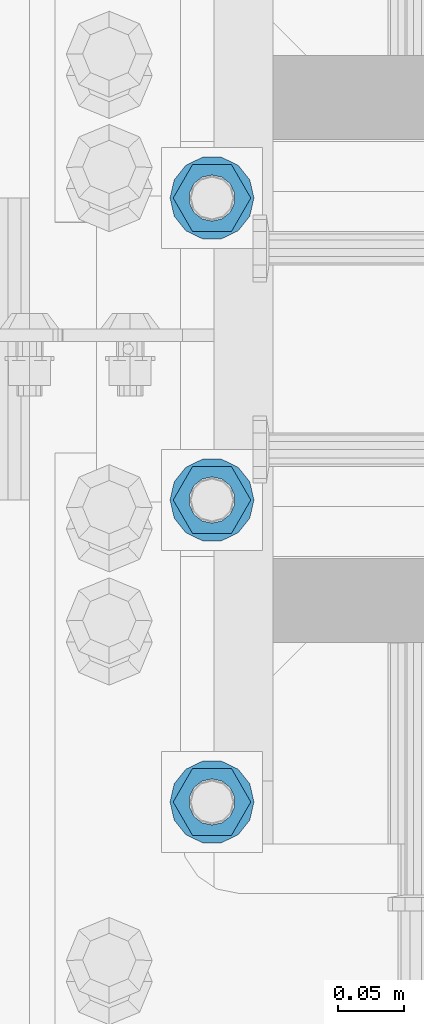
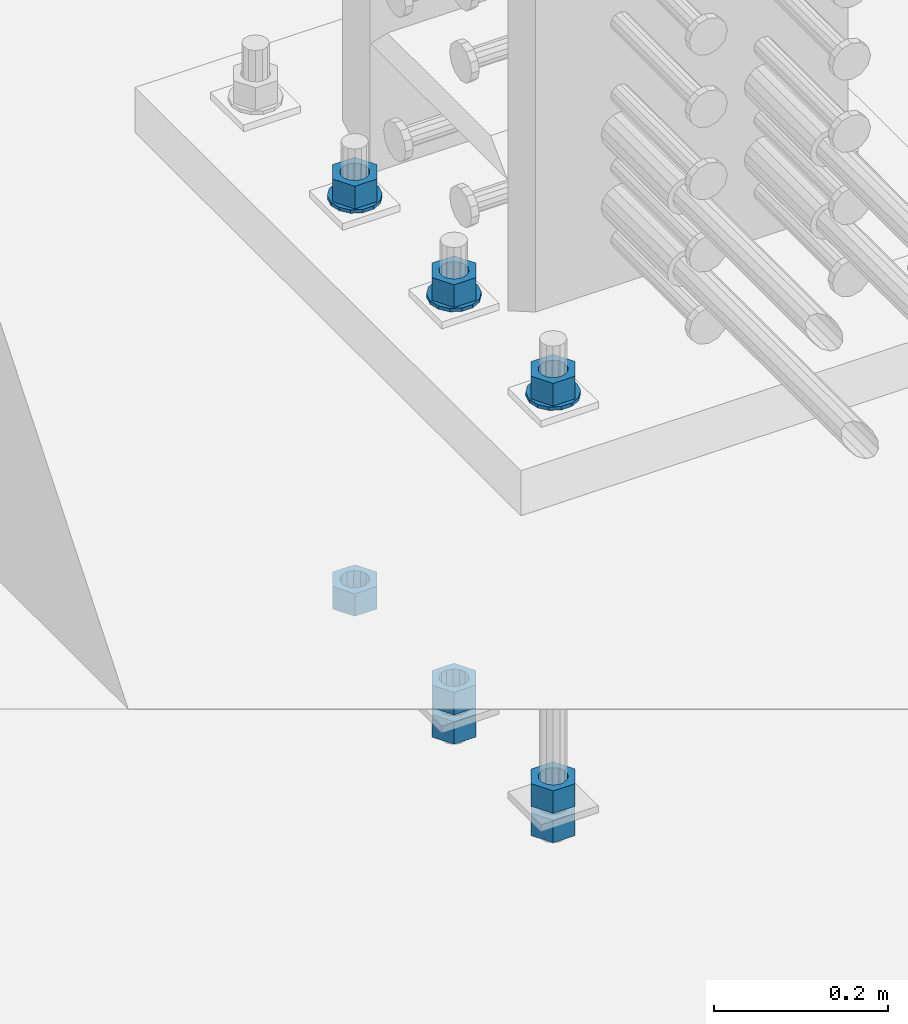
# One storey, part 1010 of 1763: 11 columns, 1 element without a shape of its own.
"""IFC2X3 building model written with IfcOpenShell, lengths in millimetres."""

import ifcopenshell
import ifcopenshell.guid

model = None  # the IFC model being written
_history = None  # IfcOwnerHistory: only IFC2X3 demands one
_inside = {}  # id of a spatial element -> (the spatial element, [elements in it])
_under = {}  # id of a project, library or spatial element -> (it, [spatial elements below it])
_declared = {}  # id of a project -> (the project, [libraries it declares])
_typed = {}  # id of a type object -> (the type object, [elements of that type])
_made_of = {}  # id of a material, layer set ... -> (it, [elements and type objects made of it])


def new_model(schema):
    """Start an empty IFC model of exactly this schema.

    Asked for "IFC4X3", IfcOpenShell would pick the latest addendum, in which some entities
    have other attributes; the version numbers below select the first issue.
    IFC2X3 requires an IfcOwnerHistory on every rooted entity: one is made here for all.
    """
    global model, _history
    if schema == "IFC4X3":
        model = ifcopenshell.file(schema_version=(4, 3, 0, 0))
    else:
        model = ifcopenshell.file(schema=schema)
    _inside.clear()
    _under.clear()
    _declared.clear()
    _typed.clear()
    _made_of.clear()
    _history = None
    if model.schema == "IFC2X3":
        org = make("IfcOrganization", Name="unknown")
        user = make(
            "IfcPersonAndOrganization",
            ThePerson=make("IfcPerson", FamilyName="unknown"),
            TheOrganization=org,
        )
        app = make(
            "IfcApplication",
            ApplicationDeveloper=org,
            Version="unknown",
            ApplicationFullName="unknown",
            ApplicationIdentifier="unknown",
        )
        _history = make(
            "IfcOwnerHistory",
            OwningUser=user,
            OwningApplication=app,
            ChangeAction="ADDED",
            CreationDate=0,
        )
    return model


def make(cls, **values):
    """One entity of the class cls with the attributes given. An attribute that is None is left unset."""
    return model.create_entity(
        cls, **{name: value for name, value in values.items() if value is not None}
    )


def rooted(cls, **values):
    """An entity with a GlobalId (a new one), such as an element, a storey or a relation."""
    return make(cls, GlobalId=ifcopenshell.guid.new(), OwnerHistory=_history, **values)


def si_unit(unit_type, name, prefix=None):
    """IfcSIUnit, for example si_unit("LENGTHUNIT", "METRE", prefix="MILLI")."""
    return make("IfcSIUnit", UnitType=unit_type, Prefix=prefix, Name=name)


def assignment(units):
    """IfcUnitAssignment: the units of a project."""
    return None if units is None else make("IfcUnitAssignment", Units=units)


def point(xyz):
    """IfcCartesianPoint."""
    return None if xyz is None else make("IfcCartesianPoint", Coordinates=xyz)


def direction(xyz):
    """IfcDirection."""
    return None if xyz is None else make("IfcDirection", DirectionRatios=xyz)


def frame(location, z_axis=None, x_axis=None):
    """IfcAxis2Placement3D, a coordinate frame: its origin and axes. An axis left out is left unset."""
    return make(
        "IfcAxis2Placement3D",
        Location=point(location),
        Axis=direction(z_axis),
        RefDirection=direction(x_axis),
    )


def origin_with_axes():
    """The frame at (0, 0, 0) with the z axis (0, 0, 1) and the x axis (1, 0, 0) written out."""
    return frame((0.0, 0.0, 0.0), z_axis=(0.0, 0.0, 1.0), x_axis=(1.0, 0.0, 0.0))


def place(relative_to, where):
    """IfcLocalPlacement: puts the frame where relative to a parent placement (None: the world)."""
    return make(
        "IfcLocalPlacement", PlacementRelTo=relative_to, RelativePlacement=where
    )


def context(
    kind, dimensions, precision=None, world=None, true_north=None, identifier=None
):
    """IfcGeometricRepresentationContext, for example the 3D "Model" context."""
    return make(
        "IfcGeometricRepresentationContext",
        ContextIdentifier=identifier,
        ContextType=kind,
        CoordinateSpaceDimension=dimensions,
        Precision=precision,
        WorldCoordinateSystem=world,
        TrueNorth=true_north,
    )


def subcontext(parent, identifier, kind, view, scale=None):
    """IfcGeometricRepresentationSubContext, for example "Body" below "Model"."""
    return make(
        "IfcGeometricRepresentationSubContext",
        ContextIdentifier=identifier,
        ContextType=kind,
        ParentContext=parent,
        TargetScale=scale,
        TargetView=view,
    )


def project(units=None, contexts=None):
    """IfcProject with its units and contexts."""
    return rooted(
        "IfcProject",
        Name="project",
        RepresentationContexts=contexts,
        UnitsInContext=assignment(units),
    )


def spatial(cls, under=None, at=None, **own):
    """A site, building, storey or space (cls), placed at a placement, below another one or the project."""
    s = rooted(cls, ObjectPlacement=at, **own)
    if under is not None:
        _under.setdefault(under.id(), (under, []))[1].append(s)
    return s


def faces_of(points, faces, orient=None, outer=None):
    """IfcFace entities. A face is a list of loops; a loop is a list of indices into points, from 0.

    orient and outer hold one flag for each loop. By default every Orientation is true, the
    first loop of a face is its IfcFaceOuterBound and the others are IfcFaceBound.
    """
    made = []
    for i, loops in enumerate(faces):
        bounds = []
        for j, loop in enumerate(loops):
            is_outer = j == 0 if outer is None else outer[i][j]
            bounds.append(
                make(
                    "IfcFaceOuterBound" if is_outer else "IfcFaceBound",
                    Bound=make("IfcPolyLoop", Polygon=[points[k] for k in loop]),
                    Orientation=True if orient is None else orient[i][j],
                )
            )
        made.append(make("IfcFace", Bounds=bounds))
    return made


def faceted_brep(points, faces, orient=None, outer=None, voids=None):
    """IfcFacetedBrep: a solid bounded by flat faces; with voids (closed shells), ...WithVoids."""
    shared = [point(p) for p in points]
    hull = make("IfcClosedShell", CfsFaces=faces_of(shared, faces, orient, outer))
    if voids is None:
        return make("IfcFacetedBrep", Outer=hull)
    return make(
        "IfcFacetedBrepWithVoids",
        Outer=hull,
        Voids=[
            make(cls, CfsFaces=faces_of(shared, fs, o, b)) for cls, fs, o, b in voids
        ],
    )


def shape(context_of_items, identifier, shape_type, items):
    """IfcShapeRepresentation: the items that make up one representation, for example the "Body"."""
    return make(
        "IfcShapeRepresentation",
        ContextOfItems=context_of_items,
        RepresentationIdentifier=identifier,
        RepresentationType=shape_type,
        Items=items,
    )


def material(Name=None, Category=None):
    """IfcMaterial."""
    return make("IfcMaterial", Name=Name, Category=Category)


def made_of(thing, what):
    """Note that an element or type object is made of a material, layer set ...; save() writes the relation."""
    if what is not None:
        _made_of.setdefault(what.id(), (what, []))[1].append(thing)
    return thing


def type_object(cls, material=None, **own):
    """A type object (cls), such as IfcWallType, which elements share."""
    return made_of(rooted(cls, **own), material)


def element(
    cls,
    number,
    at=None,
    inside=None,
    cuts=None,
    type_object=None,
    material=None,
    context=None,
    identifier="Body",
    shape_type=None,
    held_by="IfcProductDefinitionShape",
    body=None,
    shapes=None,
    **own,
):
    """One element of the class cls, such as IfcWall. Its Tag is "e" and its number.

    at: its placement. inside: the storey or other place that contains it. cuts: it is an
    opening in that element (IfcRelVoidsElement). A single representation is given by context,
    identifier, shape_type and body (its items); several are given by shapes. held_by: the class
    of the entity that holds the representations. save() writes the other relations.
    """
    e = rooted(cls, Tag="e%d" % number, ObjectPlacement=at, **own)
    if body is not None:
        shapes = [shape(context, identifier, shape_type, body)]
    if shapes is not None:
        e.Representation = make(held_by, Representations=shapes)
    if inside is not None:
        _inside.setdefault(inside.id(), (inside, []))[1].append(e)
    if cuts is not None:
        rooted(
            "IfcRelVoidsElement", RelatingBuildingElement=cuts, RelatedOpeningElement=e
        )
    if type_object is not None:
        _typed.setdefault(type_object.id(), (type_object, []))[1].append(e)
    return made_of(e, material)


def aggregate(whole, parts):
    """IfcRelAggregates: a whole, such as a stair, and the parts it consists of."""
    return rooted("IfcRelAggregates", RelatingObject=whole, RelatedObjects=parts)


def save(model, path):
    """Write the relations noted so far, then the file.

    IfcRelAggregates (storeys below a building ...), IfcRelContainedInSpatialStructure (elements
    in a storey), IfcRelDefinesByType, IfcRelAssociatesMaterial and IfcRelDeclares: one each for
    every whole, place, type object, material and project.
    """
    for whole, parts in _under.values():
        aggregate(whole, parts)
    for where, things in _inside.values():
        rooted(
            "IfcRelContainedInSpatialStructure",
            RelatedElements=things,
            RelatingStructure=where,
        )
    for kind, things in _typed.values():
        rooted("IfcRelDefinesByType", RelatedObjects=things, RelatingType=kind)
    for what, things in _made_of.values():
        rooted("IfcRelAssociatesMaterial", RelatedObjects=things, RelatingMaterial=what)
    for by, libraries in _declared.values():
        rooted("IfcRelDeclares", RelatingContext=by, RelatedDefinitions=libraries)
    model.write(path)


model = new_model("IFC2X3")

# Units and contexts
model_context = context("Model", 3, precision=1e-05, world=origin_with_axes())
body_context = subcontext(model_context, "Body", "Model", "MODEL_VIEW")
ifc_project = project(units=[si_unit("LENGTHUNIT", "METRE", prefix="MILLI"), si_unit("AREAUNIT", "SQUARE_METRE"), si_unit("VOLUMEUNIT", "CUBIC_METRE"), si_unit("MASSUNIT", "GRAM", prefix="KILO"), si_unit("TIMEUNIT", "SECOND"), si_unit("PLANEANGLEUNIT", "RADIAN"), si_unit("SOLIDANGLEUNIT", "STERADIAN"), si_unit("THERMODYNAMICTEMPERATUREUNIT", "DEGREE_CELSIUS"), si_unit("LUMINOUSINTENSITYUNIT", "LUMEN")], contexts=[model_context])

# Site, building, storey
site_placement = place(None, origin_with_axes())
site = spatial("IfcSite", under=ifc_project, at=site_placement, CompositionType="ELEMENT")
building_placement = place(site_placement, origin_with_axes())
building = spatial("IfcBuilding", under=site, at=building_placement, Name="Undefined", CompositionType="ELEMENT")
storey_placement = place(building_placement, origin_with_axes())
storey = spatial("IfcBuildingStorey", under=building, at=storey_placement, Name="Undefined", CompositionType="ELEMENT", Elevation=0.0)

# Assembly, columns
assembly_placement = place(storey_placement, origin_with_axes())
assembly = element("IfcElementAssembly", 1, at=assembly_placement, inside=storey, Name="TEMPLATE", AssemblyPlace="NOTDEFINED", PredefinedType="RIGID_FRAME")
ifc_material_1 = material(Name="STEEL/A563")
column_type_1 = type_object("IfcColumnType", Name="1-1/4_HEAVY_HEX_NUT", PredefinedType="NOTDEFINED")
column_1_placement = place(assembly_placement, frame((-24281.8372736984, 114.299999999998, 3957.6375), z_axis=(0.0, -1.0, 0.0), x_axis=(0.0, 0.0, -1.0)))
column_1 = element("IfcColumn", 2, at=column_1_placement, type_object=column_type_1, material=ifc_material_1, Name="NUT", ObjectType="1-1/4_HEAVY_HEX_NUT", context=body_context, shape_type="Brep", body=[
    faceted_brep([(0.0, -29.3700008392334, 0.0), (0.0, -14.6800003051758, -25.4300003051758), (31.75, -14.6800003051758, -25.4300003051758), (31.75, -29.3700008392334, 0.0), (0.0, 14.6800003051758, -25.4300003051758), (31.75, 14.6800003051758, -25.4300003051758), (0.0, 29.3700008392334, 0.0), (31.75, 29.3700008392334, 0.0), (0.0, 14.6800003051758, 25.4300003051758), (31.75, 14.6800003051758, 25.4300003051758), (0.0, -14.6800003051758, 25.4300003051758), (31.75, -14.6800003051758, 25.4300003051758), (0.0, 0.0, 17.4599990844727), (0.0, 7.57560968776022, 15.730915608714), (31.75, 7.57560968775942, 15.7309156087145), (31.75, 0.0, 17.4599990844727), (0.0, 13.6507769681037, 10.8861313696252), (31.75, 13.6507769681048, 10.8861313696314), (0.0, 17.0222404541215, 3.88521530314756), (31.75, 17.02224045412, 3.88521530315316), (0.0, 17.0222404541215, -3.88521530314756), (31.75, 17.02224045412, -3.88521530315332), (0.0, 13.6507769681037, -10.8861313696252), (31.75, 13.6507769681048, -10.8861313696316), (0.0, 7.57560968776022, -15.730915608714), (31.75, 7.57560968775942, -15.7309156087146), (0.0, 0.0, -17.4599990844727), (31.75, 0.0, -17.4599990844727), (0.0, -7.57560968776022, -15.730915608714), (31.75, -7.57560968775942, -15.7309156087145), (0.0, -13.6507769681037, -10.8861313696252), (31.75, -13.6507769681048, -10.8861313696314), (0.0, -17.0222404541215, -3.88521530314756), (31.75, -17.02224045412, -3.88521530315316), (0.0, -17.0222404541215, 3.88521530314756), (31.75, -17.02224045412, 3.88521530315332), (0.0, -13.6507769681037, 10.8861313696252), (31.75, -13.6507769681048, 10.8861313696316), (0.0, -7.57560968776022, 15.730915608714), (31.75, -7.57560968775942, 15.7309156087146)], [[[0, 1, 2, 3]], [[1, 4, 5, 2]], [[4, 6, 7, 5]], [[6, 8, 9, 7]], [[8, 10, 11, 9]], [[10, 0, 3, 11]], [[12, 13, 14, 15]], [[13, 16, 17, 14]], [[16, 18, 19, 17]], [[18, 20, 21, 19]], [[20, 22, 23, 21]], [[22, 24, 25, 23]], [[24, 26, 27, 25]], [[26, 28, 29, 27]], [[28, 30, 31, 29]], [[30, 32, 33, 31]], [[32, 34, 35, 33]], [[34, 36, 37, 35]], [[36, 38, 39, 37]], [[38, 12, 15, 39]], [[5, 7, 9, 11, 3, 2], [17, 19, 21, 23, 25, 27, 29, 31, 33, 35, 37, 39, 15, 14]], [[10, 8, 6, 4, 1, 0], [38, 36, 34, 32, 30, 28, 26, 24, 22, 20, 18, 16, 13, 12]]]),
])
column_2_placement = place(assembly_placement, frame((-24281.8372736984, 114.299999999998, 3384.55), z_axis=(0.0, -1.0, 0.0), x_axis=(0.0, 0.0, -1.0)))
column_2 = element("IfcColumn", 3, at=column_2_placement, type_object=column_type_1, material=ifc_material_1, Name="NUT", ObjectType="1-1/4_HEAVY_HEX_NUT", context=body_context, shape_type="Brep", body=[
    faceted_brep([(0.0, -29.3700008392334, 0.0), (0.0, -14.6800003051758, -25.4300003051758), (31.75, -14.6800003051758, -25.4300003051758), (31.75, -29.3700008392334, 0.0), (0.0, 14.6800003051758, -25.4300003051758), (31.75, 14.6800003051758, -25.4300003051758), (0.0, 29.3700008392334, 0.0), (31.75, 29.3700008392334, 0.0), (0.0, 14.6800003051758, 25.4300003051758), (31.75, 14.6800003051758, 25.4300003051758), (0.0, -14.6800003051758, 25.4300003051758), (31.75, -14.6800003051758, 25.4300003051758), (0.0, 0.0, 17.4599990844727), (0.0, 7.57560968776022, 15.730915608714), (31.75, 7.57560968775942, 15.7309156087145), (31.75, 0.0, 17.4599990844727), (0.0, 13.6507769681037, 10.8861313696252), (31.75, 13.6507769681048, 10.8861313696314), (0.0, 17.0222404541215, 3.88521530314756), (31.75, 17.02224045412, 3.88521530315316), (0.0, 17.0222404541215, -3.88521530314756), (31.75, 17.02224045412, -3.88521530315332), (0.0, 13.6507769681037, -10.8861313696252), (31.75, 13.6507769681048, -10.8861313696316), (0.0, 7.57560968776022, -15.730915608714), (31.75, 7.57560968775942, -15.7309156087146), (0.0, 0.0, -17.4599990844727), (31.75, 0.0, -17.4599990844727), (0.0, -7.57560968776022, -15.730915608714), (31.75, -7.57560968775942, -15.7309156087145), (0.0, -13.6507769681037, -10.8861313696252), (31.75, -13.6507769681048, -10.8861313696314), (0.0, -17.0222404541215, -3.88521530314756), (31.75, -17.02224045412, -3.88521530315316), (0.0, -17.0222404541215, 3.88521530314756), (31.75, -17.02224045412, 3.88521530315332), (0.0, -13.6507769681037, 10.8861313696252), (31.75, -13.6507769681048, 10.8861313696316), (0.0, -7.57560968776022, 15.730915608714), (31.75, -7.57560968775942, 15.7309156087146)], [[[0, 1, 2, 3]], [[1, 4, 5, 2]], [[4, 6, 7, 5]], [[6, 8, 9, 7]], [[8, 10, 11, 9]], [[10, 0, 3, 11]], [[12, 13, 14, 15]], [[13, 16, 17, 14]], [[16, 18, 19, 17]], [[18, 20, 21, 19]], [[20, 22, 23, 21]], [[22, 24, 25, 23]], [[24, 26, 27, 25]], [[26, 28, 29, 27]], [[28, 30, 31, 29]], [[30, 32, 33, 31]], [[32, 34, 35, 33]], [[34, 36, 37, 35]], [[36, 38, 39, 37]], [[38, 12, 15, 39]], [[5, 7, 9, 11, 3, 2], [17, 19, 21, 23, 25, 27, 29, 31, 33, 35, 37, 39, 15, 14]], [[10, 8, 6, 4, 1, 0], [38, 36, 34, 32, 30, 28, 26, 24, 22, 20, 18, 16, 13, 12]]]),
])
column_3_placement = place(assembly_placement, frame((-24281.8372736984, 114.299999999998, 3343.275), z_axis=(0.0, -1.0, 0.0), x_axis=(0.0, 0.0, -1.0)))
column_3 = element("IfcColumn", 4, at=column_3_placement, type_object=column_type_1, material=ifc_material_1, Name="NUT", ObjectType="1-1/4_HEAVY_HEX_NUT", context=body_context, shape_type="Brep", body=[
    faceted_brep([(0.0, -29.3700008392334, 0.0), (0.0, -14.6800003051758, -25.4300003051758), (31.75, -14.6800003051758, -25.4300003051758), (31.75, -29.3700008392334, 0.0), (0.0, 14.6800003051758, -25.4300003051758), (31.75, 14.6800003051758, -25.4300003051758), (0.0, 29.3700008392334, 0.0), (31.75, 29.3700008392334, 0.0), (0.0, 14.6800003051758, 25.4300003051758), (31.75, 14.6800003051758, 25.4300003051758), (0.0, -14.6800003051758, 25.4300003051758), (31.75, -14.6800003051758, 25.4300003051758), (0.0, 0.0, 17.4599990844727), (0.0, 7.57560968776022, 15.730915608714), (31.75, 7.57560968775942, 15.7309156087145), (31.75, 0.0, 17.4599990844727), (0.0, 13.6507769681037, 10.8861313696252), (31.75, 13.6507769681048, 10.8861313696314), (0.0, 17.0222404541215, 3.88521530314756), (31.75, 17.02224045412, 3.88521530315316), (0.0, 17.0222404541215, -3.88521530314756), (31.75, 17.02224045412, -3.88521530315332), (0.0, 13.6507769681037, -10.8861313696252), (31.75, 13.6507769681048, -10.8861313696316), (0.0, 7.57560968776022, -15.730915608714), (31.75, 7.57560968775942, -15.7309156087146), (0.0, 0.0, -17.4599990844727), (31.75, 0.0, -17.4599990844727), (0.0, -7.57560968776022, -15.730915608714), (31.75, -7.57560968775942, -15.7309156087145), (0.0, -13.6507769681037, -10.8861313696252), (31.75, -13.6507769681048, -10.8861313696314), (0.0, -17.0222404541215, -3.88521530314756), (31.75, -17.02224045412, -3.88521530315316), (0.0, -17.0222404541215, 3.88521530314756), (31.75, -17.02224045412, 3.88521530315332), (0.0, -13.6507769681037, 10.8861313696252), (31.75, -13.6507769681048, 10.8861313696316), (0.0, -7.57560968776022, 15.730915608714), (31.75, -7.57560968775942, 15.7309156087146)], [[[0, 1, 2, 3]], [[1, 4, 5, 2]], [[4, 6, 7, 5]], [[6, 8, 9, 7]], [[8, 10, 11, 9]], [[10, 0, 3, 11]], [[12, 13, 14, 15]], [[13, 16, 17, 14]], [[16, 18, 19, 17]], [[18, 20, 21, 19]], [[20, 22, 23, 21]], [[22, 24, 25, 23]], [[24, 26, 27, 25]], [[26, 28, 29, 27]], [[28, 30, 31, 29]], [[30, 32, 33, 31]], [[32, 34, 35, 33]], [[34, 36, 37, 35]], [[36, 38, 39, 37]], [[38, 12, 15, 39]], [[5, 7, 9, 11, 3, 2], [17, 19, 21, 23, 25, 27, 29, 31, 33, 35, 37, 39, 15, 14]], [[10, 8, 6, 4, 1, 0], [38, 36, 34, 32, 30, 28, 26, 24, 22, 20, 18, 16, 13, 12]]]),
])
column_4_placement = place(assembly_placement, frame((-24281.8372736984, 342.899999999998, 3957.6375), z_axis=(0.0, -1.0, 0.0), x_axis=(0.0, 0.0, -1.0)))
column_4 = element("IfcColumn", 5, at=column_4_placement, type_object=column_type_1, material=ifc_material_1, Name="NUT", ObjectType="1-1/4_HEAVY_HEX_NUT", context=body_context, shape_type="Brep", body=[
    faceted_brep([(0.0, -29.3700008392334, 0.0), (0.0, -14.6800003051758, -25.4300003051758), (31.75, -14.6800003051758, -25.4300003051758), (31.75, -29.3700008392334, 0.0), (0.0, 14.6800003051758, -25.4300003051758), (31.75, 14.6800003051758, -25.4300003051758), (0.0, 29.3700008392334, 0.0), (31.75, 29.3700008392334, 0.0), (0.0, 14.6800003051758, 25.4300003051758), (31.75, 14.6800003051758, 25.4300003051758), (0.0, -14.6800003051758, 25.4300003051758), (31.75, -14.6800003051758, 25.4300003051758), (0.0, 0.0, 17.4599990844727), (0.0, 7.57560968776022, 15.730915608714), (31.75, 7.57560968775942, 15.7309156087145), (31.75, 0.0, 17.4599990844727), (0.0, 13.6507769681037, 10.8861313696252), (31.75, 13.6507769681048, 10.8861313696314), (0.0, 17.0222404541215, 3.88521530314756), (31.75, 17.02224045412, 3.88521530315316), (0.0, 17.0222404541215, -3.88521530314756), (31.75, 17.02224045412, -3.88521530315332), (0.0, 13.6507769681037, -10.8861313696252), (31.75, 13.6507769681048, -10.8861313696316), (0.0, 7.57560968776022, -15.730915608714), (31.75, 7.57560968775942, -15.7309156087146), (0.0, 0.0, -17.4599990844727), (31.75, 0.0, -17.4599990844727), (0.0, -7.57560968776022, -15.730915608714), (31.75, -7.57560968775942, -15.7309156087145), (0.0, -13.6507769681037, -10.8861313696252), (31.75, -13.6507769681048, -10.8861313696314), (0.0, -17.0222404541215, -3.88521530314756), (31.75, -17.02224045412, -3.88521530315316), (0.0, -17.0222404541215, 3.88521530314756), (31.75, -17.02224045412, 3.88521530315332), (0.0, -13.6507769681037, 10.8861313696252), (31.75, -13.6507769681048, 10.8861313696316), (0.0, -7.57560968776022, 15.730915608714), (31.75, -7.57560968775942, 15.7309156087146)], [[[0, 1, 2, 3]], [[1, 4, 5, 2]], [[4, 6, 7, 5]], [[6, 8, 9, 7]], [[8, 10, 11, 9]], [[10, 0, 3, 11]], [[12, 13, 14, 15]], [[13, 16, 17, 14]], [[16, 18, 19, 17]], [[18, 20, 21, 19]], [[20, 22, 23, 21]], [[22, 24, 25, 23]], [[24, 26, 27, 25]], [[26, 28, 29, 27]], [[28, 30, 31, 29]], [[30, 32, 33, 31]], [[32, 34, 35, 33]], [[34, 36, 37, 35]], [[36, 38, 39, 37]], [[38, 12, 15, 39]], [[5, 7, 9, 11, 3, 2], [17, 19, 21, 23, 25, 27, 29, 31, 33, 35, 37, 39, 15, 14]], [[10, 8, 6, 4, 1, 0], [38, 36, 34, 32, 30, 28, 26, 24, 22, 20, 18, 16, 13, 12]]]),
])
column_5_placement = place(assembly_placement, frame((-24281.8372736984, 342.899999999998, 3384.55), z_axis=(0.0, -1.0, 0.0), x_axis=(0.0, 0.0, -1.0)))
column_5 = element("IfcColumn", 6, at=column_5_placement, type_object=column_type_1, material=ifc_material_1, Name="NUT", ObjectType="1-1/4_HEAVY_HEX_NUT", context=body_context, shape_type="Brep", body=[
    faceted_brep([(0.0, -29.3700008392334, 0.0), (0.0, -14.6800003051758, -25.4300003051758), (31.75, -14.6800003051758, -25.4300003051758), (31.75, -29.3700008392334, 0.0), (0.0, 14.6800003051758, -25.4300003051758), (31.75, 14.6800003051758, -25.4300003051758), (0.0, 29.3700008392334, 0.0), (31.75, 29.3700008392334, 0.0), (0.0, 14.6800003051758, 25.4300003051758), (31.75, 14.6800003051758, 25.4300003051758), (0.0, -14.6800003051758, 25.4300003051758), (31.75, -14.6800003051758, 25.4300003051758), (0.0, 0.0, 17.4599990844727), (0.0, 7.57560968776022, 15.730915608714), (31.75, 7.57560968775942, 15.7309156087145), (31.75, 0.0, 17.4599990844727), (0.0, 13.6507769681037, 10.8861313696252), (31.75, 13.6507769681048, 10.8861313696314), (0.0, 17.0222404541215, 3.88521530314756), (31.75, 17.02224045412, 3.88521530315316), (0.0, 17.0222404541215, -3.88521530314756), (31.75, 17.02224045412, -3.88521530315332), (0.0, 13.6507769681037, -10.8861313696252), (31.75, 13.6507769681048, -10.8861313696316), (0.0, 7.57560968776022, -15.730915608714), (31.75, 7.57560968775942, -15.7309156087146), (0.0, 0.0, -17.4599990844727), (31.75, 0.0, -17.4599990844727), (0.0, -7.57560968776022, -15.730915608714), (31.75, -7.57560968775942, -15.7309156087145), (0.0, -13.6507769681037, -10.8861313696252), (31.75, -13.6507769681048, -10.8861313696314), (0.0, -17.0222404541215, -3.88521530314756), (31.75, -17.02224045412, -3.88521530315316), (0.0, -17.0222404541215, 3.88521530314756), (31.75, -17.02224045412, 3.88521530315332), (0.0, -13.6507769681037, 10.8861313696252), (31.75, -13.6507769681048, 10.8861313696316), (0.0, -7.57560968776022, 15.730915608714), (31.75, -7.57560968775942, 15.7309156087146)], [[[0, 1, 2, 3]], [[1, 4, 5, 2]], [[4, 6, 7, 5]], [[6, 8, 9, 7]], [[8, 10, 11, 9]], [[10, 0, 3, 11]], [[12, 13, 14, 15]], [[13, 16, 17, 14]], [[16, 18, 19, 17]], [[18, 20, 21, 19]], [[20, 22, 23, 21]], [[22, 24, 25, 23]], [[24, 26, 27, 25]], [[26, 28, 29, 27]], [[28, 30, 31, 29]], [[30, 32, 33, 31]], [[32, 34, 35, 33]], [[34, 36, 37, 35]], [[36, 38, 39, 37]], [[38, 12, 15, 39]], [[5, 7, 9, 11, 3, 2], [17, 19, 21, 23, 25, 27, 29, 31, 33, 35, 37, 39, 15, 14]], [[10, 8, 6, 4, 1, 0], [38, 36, 34, 32, 30, 28, 26, 24, 22, 20, 18, 16, 13, 12]]]),
])
column_6_placement = place(assembly_placement, frame((-24281.8372736984, 342.899999999998, 3343.275), z_axis=(0.0, -1.0, 0.0), x_axis=(0.0, 0.0, -1.0)))
column_6 = element("IfcColumn", 7, at=column_6_placement, type_object=column_type_1, material=ifc_material_1, Name="NUT", ObjectType="1-1/4_HEAVY_HEX_NUT", context=body_context, shape_type="Brep", body=[
    faceted_brep([(0.0, -29.3700008392334, 0.0), (0.0, -14.6800003051758, -25.4300003051758), (31.75, -14.6800003051758, -25.4300003051758), (31.75, -29.3700008392334, 0.0), (0.0, 14.6800003051758, -25.4300003051758), (31.75, 14.6800003051758, -25.4300003051758), (0.0, 29.3700008392334, 0.0), (31.75, 29.3700008392334, 0.0), (0.0, 14.6800003051758, 25.4300003051758), (31.75, 14.6800003051758, 25.4300003051758), (0.0, -14.6800003051758, 25.4300003051758), (31.75, -14.6800003051758, 25.4300003051758), (0.0, 0.0, 17.4599990844727), (0.0, 7.57560968776022, 15.730915608714), (31.75, 7.57560968775942, 15.7309156087145), (31.75, 0.0, 17.4599990844727), (0.0, 13.6507769681037, 10.8861313696252), (31.75, 13.6507769681048, 10.8861313696314), (0.0, 17.0222404541215, 3.88521530314756), (31.75, 17.02224045412, 3.88521530315316), (0.0, 17.0222404541215, -3.88521530314756), (31.75, 17.02224045412, -3.88521530315332), (0.0, 13.6507769681037, -10.8861313696252), (31.75, 13.6507769681048, -10.8861313696316), (0.0, 7.57560968776022, -15.730915608714), (31.75, 7.57560968775942, -15.7309156087146), (0.0, 0.0, -17.4599990844727), (31.75, 0.0, -17.4599990844727), (0.0, -7.57560968776022, -15.730915608714), (31.75, -7.57560968775942, -15.7309156087145), (0.0, -13.6507769681037, -10.8861313696252), (31.75, -13.6507769681048, -10.8861313696314), (0.0, -17.0222404541215, -3.88521530314756), (31.75, -17.02224045412, -3.88521530315316), (0.0, -17.0222404541215, 3.88521530314756), (31.75, -17.02224045412, 3.88521530315332), (0.0, -13.6507769681037, 10.8861313696252), (31.75, -13.6507769681048, 10.8861313696316), (0.0, -7.57560968776022, 15.730915608714), (31.75, -7.57560968775942, 15.7309156087146)], [[[0, 1, 2, 3]], [[1, 4, 5, 2]], [[4, 6, 7, 5]], [[6, 8, 9, 7]], [[8, 10, 11, 9]], [[10, 0, 3, 11]], [[12, 13, 14, 15]], [[13, 16, 17, 14]], [[16, 18, 19, 17]], [[18, 20, 21, 19]], [[20, 22, 23, 21]], [[22, 24, 25, 23]], [[24, 26, 27, 25]], [[26, 28, 29, 27]], [[28, 30, 31, 29]], [[30, 32, 33, 31]], [[32, 34, 35, 33]], [[34, 36, 37, 35]], [[36, 38, 39, 37]], [[38, 12, 15, 39]], [[5, 7, 9, 11, 3, 2], [17, 19, 21, 23, 25, 27, 29, 31, 33, 35, 37, 39, 15, 14]], [[10, 8, 6, 4, 1, 0], [38, 36, 34, 32, 30, 28, 26, 24, 22, 20, 18, 16, 13, 12]]]),
])
column_7_placement = place(assembly_placement, frame((-24281.8372736984, 571.499999999998, 3957.6375), z_axis=(0.0, -1.0, 0.0), x_axis=(0.0, 0.0, -1.0)))
column_7 = element("IfcColumn", 8, at=column_7_placement, type_object=column_type_1, material=ifc_material_1, Name="NUT", ObjectType="1-1/4_HEAVY_HEX_NUT", context=body_context, shape_type="Brep", body=[
    faceted_brep([(0.0, -29.3700008392334, 0.0), (0.0, -14.6800003051758, -25.4300003051758), (31.75, -14.6800003051758, -25.4300003051758), (31.75, -29.3700008392334, 0.0), (0.0, 14.6800003051758, -25.4300003051758), (31.75, 14.6800003051758, -25.4300003051758), (0.0, 29.3700008392334, 0.0), (31.75, 29.3700008392334, 0.0), (0.0, 14.6800003051758, 25.4300003051758), (31.75, 14.6800003051758, 25.4300003051758), (0.0, -14.6800003051758, 25.4300003051758), (31.75, -14.6800003051758, 25.4300003051758), (0.0, 0.0, 17.4599990844727), (0.0, 7.57560968776022, 15.730915608714), (31.75, 7.57560968775942, 15.7309156087145), (31.75, 0.0, 17.4599990844727), (0.0, 13.6507769681037, 10.8861313696252), (31.75, 13.6507769681048, 10.8861313696314), (0.0, 17.0222404541215, 3.88521530314756), (31.75, 17.02224045412, 3.88521530315316), (0.0, 17.0222404541215, -3.88521530314756), (31.75, 17.02224045412, -3.88521530315332), (0.0, 13.6507769681037, -10.8861313696252), (31.75, 13.6507769681048, -10.8861313696316), (0.0, 7.57560968776022, -15.730915608714), (31.75, 7.57560968775942, -15.7309156087146), (0.0, 0.0, -17.4599990844727), (31.75, 0.0, -17.4599990844727), (0.0, -7.57560968776022, -15.730915608714), (31.75, -7.57560968775942, -15.7309156087145), (0.0, -13.6507769681037, -10.8861313696252), (31.75, -13.6507769681048, -10.8861313696314), (0.0, -17.0222404541215, -3.88521530314756), (31.75, -17.02224045412, -3.88521530315316), (0.0, -17.0222404541215, 3.88521530314756), (31.75, -17.02224045412, 3.88521530315332), (0.0, -13.6507769681037, 10.8861313696252), (31.75, -13.6507769681048, 10.8861313696316), (0.0, -7.57560968776022, 15.730915608714), (31.75, -7.57560968775942, 15.7309156087146)], [[[0, 1, 2, 3]], [[1, 4, 5, 2]], [[4, 6, 7, 5]], [[6, 8, 9, 7]], [[8, 10, 11, 9]], [[10, 0, 3, 11]], [[12, 13, 14, 15]], [[13, 16, 17, 14]], [[16, 18, 19, 17]], [[18, 20, 21, 19]], [[20, 22, 23, 21]], [[22, 24, 25, 23]], [[24, 26, 27, 25]], [[26, 28, 29, 27]], [[28, 30, 31, 29]], [[30, 32, 33, 31]], [[32, 34, 35, 33]], [[34, 36, 37, 35]], [[36, 38, 39, 37]], [[38, 12, 15, 39]], [[5, 7, 9, 11, 3, 2], [17, 19, 21, 23, 25, 27, 29, 31, 33, 35, 37, 39, 15, 14]], [[10, 8, 6, 4, 1, 0], [38, 36, 34, 32, 30, 28, 26, 24, 22, 20, 18, 16, 13, 12]]]),
])
column_8_placement = place(assembly_placement, frame((-24281.8372736984, 571.499999999998, 3384.55), z_axis=(0.0, -1.0, 0.0), x_axis=(0.0, 0.0, -1.0)))
column_8 = element("IfcColumn", 9, at=column_8_placement, type_object=column_type_1, material=ifc_material_1, Name="NUT", ObjectType="1-1/4_HEAVY_HEX_NUT", context=body_context, shape_type="Brep", body=[
    faceted_brep([(0.0, -29.3700008392334, 0.0), (0.0, -14.6800003051758, -25.4300003051758), (31.75, -14.6800003051758, -25.4300003051758), (31.75, -29.3700008392334, 0.0), (0.0, 14.6800003051758, -25.4300003051758), (31.75, 14.6800003051758, -25.4300003051758), (0.0, 29.3700008392334, 0.0), (31.75, 29.3700008392334, 0.0), (0.0, 14.6800003051758, 25.4300003051758), (31.75, 14.6800003051758, 25.4300003051758), (0.0, -14.6800003051758, 25.4300003051758), (31.75, -14.6800003051758, 25.4300003051758), (0.0, 0.0, 17.4599990844727), (0.0, 7.57560968776022, 15.730915608714), (31.75, 7.57560968775942, 15.7309156087145), (31.75, 0.0, 17.4599990844727), (0.0, 13.6507769681037, 10.8861313696252), (31.75, 13.6507769681048, 10.8861313696314), (0.0, 17.0222404541215, 3.88521530314756), (31.75, 17.02224045412, 3.88521530315316), (0.0, 17.0222404541215, -3.88521530314756), (31.75, 17.02224045412, -3.88521530315332), (0.0, 13.6507769681037, -10.8861313696252), (31.75, 13.6507769681048, -10.8861313696316), (0.0, 7.57560968776022, -15.730915608714), (31.75, 7.57560968775942, -15.7309156087146), (0.0, 0.0, -17.4599990844727), (31.75, 0.0, -17.4599990844727), (0.0, -7.57560968776022, -15.730915608714), (31.75, -7.57560968775942, -15.7309156087145), (0.0, -13.6507769681037, -10.8861313696252), (31.75, -13.6507769681048, -10.8861313696314), (0.0, -17.0222404541215, -3.88521530314756), (31.75, -17.02224045412, -3.88521530315316), (0.0, -17.0222404541215, 3.88521530314756), (31.75, -17.02224045412, 3.88521530315332), (0.0, -13.6507769681037, 10.8861313696252), (31.75, -13.6507769681048, 10.8861313696316), (0.0, -7.57560968776022, 15.730915608714), (31.75, -7.57560968775942, 15.7309156087146)], [[[0, 1, 2, 3]], [[1, 4, 5, 2]], [[4, 6, 7, 5]], [[6, 8, 9, 7]], [[8, 10, 11, 9]], [[10, 0, 3, 11]], [[12, 13, 14, 15]], [[13, 16, 17, 14]], [[16, 18, 19, 17]], [[18, 20, 21, 19]], [[20, 22, 23, 21]], [[22, 24, 25, 23]], [[24, 26, 27, 25]], [[26, 28, 29, 27]], [[28, 30, 31, 29]], [[30, 32, 33, 31]], [[32, 34, 35, 33]], [[34, 36, 37, 35]], [[36, 38, 39, 37]], [[38, 12, 15, 39]], [[5, 7, 9, 11, 3, 2], [17, 19, 21, 23, 25, 27, 29, 31, 33, 35, 37, 39, 15, 14]], [[10, 8, 6, 4, 1, 0], [38, 36, 34, 32, 30, 28, 26, 24, 22, 20, 18, 16, 13, 12]]]),
])
ifc_material_2 = material(Name="STEEL/F436")
column_type_2 = type_object("IfcColumnType", Name="1-1/4_WASHER", PredefinedType="NOTDEFINED")
column_9_placement = place(assembly_placement, frame((-24281.8372736984, 114.299999999998, 3925.8875), z_axis=(0.0, -1.0, 0.0), x_axis=(0.0, 0.0, -1.0)))
column_9 = element("IfcColumn", 10, at=column_9_placement, type_object=column_type_2, material=ifc_material_2, Name="WASHER", ObjectType="1-1/4_WASHER", context=body_context, shape_type="Brep", body=[
    faceted_brep([(-4.54747350886464e-13, -31.7499999999964, 0.0), (0.0, -28.6057615559002, -13.7758087169827), (4.76249999999982, -28.6057615559002, -13.7758087169827), (4.76249999999982, -31.75, 0.0), (0.0, -19.795801209013, -24.8231495683602), (4.76249999999982, -19.795801209013, -24.8231495683602), (0.0, -7.06503965311276, -30.9539612117732), (4.76249999999982, -7.06503965311276, -30.9539612117732), (0.0, 7.06503965311276, -30.9539612117732), (4.76249999999982, 7.06503965311276, -30.9539612117732), (0.0, 19.7958012090166, -24.8231495683602), (4.76249999999982, 19.7958012090166, -24.8231495683602), (0.0, 28.6057615559039, -13.7758087169827), (4.76249999999982, 28.6057615559039, -13.7758087169827), (-5.91171556152403e-12, 31.7499999999891, 0.0), (4.76249999999982, 31.75, 0.0), (0.0, 28.6057615559002, 13.7758087169827), (4.76249999999982, 28.6057615559002, 13.7758087169827), (0.0, 19.795801209013, 24.8231495683602), (4.76249999999982, 19.795801209013, 24.8231495683602), (0.0, 7.06503965311276, 30.9539612117731), (4.76249999999982, 7.06503965311276, 30.9539612117731), (0.0, -7.06503965311276, 30.9539612117731), (4.76249999999982, -7.06503965311276, 30.9539612117731), (0.0, -19.7958012090166, 24.8231495683602), (4.76249999999982, -19.7958012090166, 24.8231495683602), (0.0, -28.6057615559039, 13.7758087169827), (4.76249999999982, -28.6057615559039, 13.7758087169827), (0.0, 0.0, 17.4599990844727), (0.0, 7.57560968776022, 15.730915608714), (4.76249999999982, 7.57560968775942, 15.7309156087145), (4.76249999999982, 0.0, 17.4599990844727), (0.0, 13.6507769681037, 10.8861313696252), (4.76249999999982, 13.6507769681048, 10.8861313696314), (0.0, 17.0222404541215, 3.88521530314756), (4.76249999999982, 17.02224045412, 3.88521530315316), (0.0, 17.0222404541215, -3.88521530314756), (4.76249999999982, 17.02224045412, -3.88521530315332), (0.0, 13.6507769681037, -10.8861313696252), (4.76249999999982, 13.6507769681048, -10.8861313696316), (0.0, 7.57560968776022, -15.730915608714), (4.76249999999982, 7.57560968775942, -15.7309156087146), (0.0, 0.0, -17.4599990844727), (4.76249999999982, 0.0, -17.4599990844727), (0.0, -7.57560968776022, -15.730915608714), (4.76249999999982, -7.57560968775942, -15.7309156087145), (0.0, -13.6507769681037, -10.8861313696252), (4.76249999999982, -13.6507769681048, -10.8861313696314), (0.0, -17.0222404541215, -3.88521530314756), (4.76249999999982, -17.02224045412, -3.88521530315316), (0.0, -17.0222404541215, 3.88521530314756), (4.76249999999982, -17.02224045412, 3.88521530315332), (0.0, -13.6507769681037, 10.8861313696252), (4.76249999999982, -13.6507769681048, 10.8861313696316), (0.0, -7.57560968776022, 15.730915608714), (4.76249999999982, -7.57560968775942, 15.7309156087146)], [[[0, 1, 2, 3]], [[1, 4, 5, 2]], [[4, 6, 7, 5]], [[6, 8, 9, 7]], [[8, 10, 11, 9]], [[10, 12, 13, 11]], [[12, 14, 15, 13]], [[14, 16, 17, 15]], [[16, 18, 19, 17]], [[18, 20, 21, 19]], [[20, 22, 23, 21]], [[22, 24, 25, 23]], [[24, 26, 27, 25]], [[26, 0, 3, 27]], [[28, 29, 30, 31]], [[29, 32, 33, 30]], [[32, 34, 35, 33]], [[34, 36, 37, 35]], [[36, 38, 39, 37]], [[38, 40, 41, 39]], [[40, 42, 43, 41]], [[42, 44, 45, 43]], [[44, 46, 47, 45]], [[46, 48, 49, 47]], [[48, 50, 51, 49]], [[50, 52, 53, 51]], [[52, 54, 55, 53]], [[54, 28, 31, 55]], [[5, 7, 9, 11, 13, 15, 17, 19, 21, 23, 25, 27, 3, 2], [33, 35, 37, 39, 41, 43, 45, 47, 49, 51, 53, 55, 31, 30]], [[26, 24, 22, 20, 18, 16, 14, 12, 10, 8, 6, 4, 1, 0], [54, 52, 50, 48, 46, 44, 42, 40, 38, 36, 34, 32, 29, 28]]]),
])
column_10_placement = place(assembly_placement, frame((-24281.8372736984, 342.899999999998, 3925.8875), z_axis=(0.0, -1.0, 0.0), x_axis=(0.0, 0.0, -1.0)))
column_10 = element("IfcColumn", 11, at=column_10_placement, type_object=column_type_2, material=ifc_material_2, Name="WASHER", ObjectType="1-1/4_WASHER", context=body_context, shape_type="Brep", body=[
    faceted_brep([(-4.54747350886464e-13, -31.7499999999964, 0.0), (0.0, -28.6057615559002, -13.7758087169827), (4.76249999999982, -28.6057615559002, -13.7758087169827), (4.76249999999982, -31.75, 0.0), (0.0, -19.795801209013, -24.8231495683602), (4.76249999999982, -19.795801209013, -24.8231495683602), (0.0, -7.06503965311276, -30.9539612117732), (4.76249999999982, -7.06503965311276, -30.9539612117732), (0.0, 7.06503965311276, -30.9539612117732), (4.76249999999982, 7.06503965311276, -30.9539612117732), (0.0, 19.7958012090166, -24.8231495683602), (4.76249999999982, 19.7958012090166, -24.8231495683602), (0.0, 28.6057615559039, -13.7758087169827), (4.76249999999982, 28.6057615559039, -13.7758087169827), (-5.91171556152403e-12, 31.7499999999891, 0.0), (4.76249999999982, 31.75, 0.0), (0.0, 28.6057615559002, 13.7758087169827), (4.76249999999982, 28.6057615559002, 13.7758087169827), (0.0, 19.795801209013, 24.8231495683602), (4.76249999999982, 19.795801209013, 24.8231495683602), (0.0, 7.06503965311276, 30.9539612117731), (4.76249999999982, 7.06503965311276, 30.9539612117731), (0.0, -7.06503965311276, 30.9539612117731), (4.76249999999982, -7.06503965311276, 30.9539612117731), (0.0, -19.7958012090166, 24.8231495683602), (4.76249999999982, -19.7958012090166, 24.8231495683602), (0.0, -28.6057615559039, 13.7758087169827), (4.76249999999982, -28.6057615559039, 13.7758087169827), (0.0, 0.0, 17.4599990844727), (0.0, 7.57560968776022, 15.730915608714), (4.76249999999982, 7.57560968775942, 15.7309156087145), (4.76249999999982, 0.0, 17.4599990844727), (0.0, 13.6507769681037, 10.8861313696252), (4.76249999999982, 13.6507769681048, 10.8861313696314), (0.0, 17.0222404541215, 3.88521530314756), (4.76249999999982, 17.02224045412, 3.88521530315316), (0.0, 17.0222404541215, -3.88521530314756), (4.76249999999982, 17.02224045412, -3.88521530315332), (0.0, 13.6507769681037, -10.8861313696252), (4.76249999999982, 13.6507769681048, -10.8861313696316), (0.0, 7.57560968776022, -15.730915608714), (4.76249999999982, 7.57560968775942, -15.7309156087146), (0.0, 0.0, -17.4599990844727), (4.76249999999982, 0.0, -17.4599990844727), (0.0, -7.57560968776022, -15.730915608714), (4.76249999999982, -7.57560968775942, -15.7309156087145), (0.0, -13.6507769681037, -10.8861313696252), (4.76249999999982, -13.6507769681048, -10.8861313696314), (0.0, -17.0222404541215, -3.88521530314756), (4.76249999999982, -17.02224045412, -3.88521530315316), (0.0, -17.0222404541215, 3.88521530314756), (4.76249999999982, -17.02224045412, 3.88521530315332), (0.0, -13.6507769681037, 10.8861313696252), (4.76249999999982, -13.6507769681048, 10.8861313696316), (0.0, -7.57560968776022, 15.730915608714), (4.76249999999982, -7.57560968775942, 15.7309156087146)], [[[0, 1, 2, 3]], [[1, 4, 5, 2]], [[4, 6, 7, 5]], [[6, 8, 9, 7]], [[8, 10, 11, 9]], [[10, 12, 13, 11]], [[12, 14, 15, 13]], [[14, 16, 17, 15]], [[16, 18, 19, 17]], [[18, 20, 21, 19]], [[20, 22, 23, 21]], [[22, 24, 25, 23]], [[24, 26, 27, 25]], [[26, 0, 3, 27]], [[28, 29, 30, 31]], [[29, 32, 33, 30]], [[32, 34, 35, 33]], [[34, 36, 37, 35]], [[36, 38, 39, 37]], [[38, 40, 41, 39]], [[40, 42, 43, 41]], [[42, 44, 45, 43]], [[44, 46, 47, 45]], [[46, 48, 49, 47]], [[48, 50, 51, 49]], [[50, 52, 53, 51]], [[52, 54, 55, 53]], [[54, 28, 31, 55]], [[5, 7, 9, 11, 13, 15, 17, 19, 21, 23, 25, 27, 3, 2], [33, 35, 37, 39, 41, 43, 45, 47, 49, 51, 53, 55, 31, 30]], [[26, 24, 22, 20, 18, 16, 14, 12, 10, 8, 6, 4, 1, 0], [54, 52, 50, 48, 46, 44, 42, 40, 38, 36, 34, 32, 29, 28]]]),
])
column_11_placement = place(assembly_placement, frame((-24281.8372736984, 571.499999999998, 3925.8875), z_axis=(0.0, -1.0, 0.0), x_axis=(0.0, 0.0, -1.0)))
column_11 = element("IfcColumn", 12, at=column_11_placement, type_object=column_type_2, material=ifc_material_2, Name="WASHER", ObjectType="1-1/4_WASHER", context=body_context, shape_type="Brep", body=[
    faceted_brep([(-4.54747350886464e-13, -31.7499999999964, 0.0), (0.0, -28.6057615559002, -13.7758087169827), (4.76249999999982, -28.6057615559002, -13.7758087169827), (4.76249999999982, -31.75, 0.0), (0.0, -19.795801209013, -24.8231495683602), (4.76249999999982, -19.795801209013, -24.8231495683602), (0.0, -7.06503965311276, -30.9539612117732), (4.76249999999982, -7.06503965311276, -30.9539612117732), (0.0, 7.06503965311276, -30.9539612117732), (4.76249999999982, 7.06503965311276, -30.9539612117732), (0.0, 19.7958012090166, -24.8231495683602), (4.76249999999982, 19.7958012090166, -24.8231495683602), (0.0, 28.6057615559039, -13.7758087169827), (4.76249999999982, 28.6057615559039, -13.7758087169827), (-5.91171556152403e-12, 31.7499999999891, 0.0), (4.76249999999982, 31.75, 0.0), (0.0, 28.6057615559002, 13.7758087169827), (4.76249999999982, 28.6057615559002, 13.7758087169827), (0.0, 19.795801209013, 24.8231495683602), (4.76249999999982, 19.795801209013, 24.8231495683602), (0.0, 7.06503965311276, 30.9539612117731), (4.76249999999982, 7.06503965311276, 30.9539612117731), (0.0, -7.06503965311276, 30.9539612117731), (4.76249999999982, -7.06503965311276, 30.9539612117731), (0.0, -19.7958012090166, 24.8231495683602), (4.76249999999982, -19.7958012090166, 24.8231495683602), (0.0, -28.6057615559039, 13.7758087169827), (4.76249999999982, -28.6057615559039, 13.7758087169827), (0.0, 0.0, 17.4599990844727), (0.0, 7.57560968776022, 15.730915608714), (4.76249999999982, 7.57560968775942, 15.7309156087145), (4.76249999999982, 0.0, 17.4599990844727), (0.0, 13.6507769681037, 10.8861313696252), (4.76249999999982, 13.6507769681048, 10.8861313696314), (0.0, 17.0222404541215, 3.88521530314756), (4.76249999999982, 17.02224045412, 3.88521530315316), (0.0, 17.0222404541215, -3.88521530314756), (4.76249999999982, 17.02224045412, -3.88521530315332), (0.0, 13.6507769681037, -10.8861313696252), (4.76249999999982, 13.6507769681048, -10.8861313696316), (0.0, 7.57560968776022, -15.730915608714), (4.76249999999982, 7.57560968775942, -15.7309156087146), (0.0, 0.0, -17.4599990844727), (4.76249999999982, 0.0, -17.4599990844727), (0.0, -7.57560968776022, -15.730915608714), (4.76249999999982, -7.57560968775942, -15.7309156087145), (0.0, -13.6507769681037, -10.8861313696252), (4.76249999999982, -13.6507769681048, -10.8861313696314), (0.0, -17.0222404541215, -3.88521530314756), (4.76249999999982, -17.02224045412, -3.88521530315316), (0.0, -17.0222404541215, 3.88521530314756), (4.76249999999982, -17.02224045412, 3.88521530315332), (0.0, -13.6507769681037, 10.8861313696252), (4.76249999999982, -13.6507769681048, 10.8861313696316), (0.0, -7.57560968776022, 15.730915608714), (4.76249999999982, -7.57560968775942, 15.7309156087146)], [[[0, 1, 2, 3]], [[1, 4, 5, 2]], [[4, 6, 7, 5]], [[6, 8, 9, 7]], [[8, 10, 11, 9]], [[10, 12, 13, 11]], [[12, 14, 15, 13]], [[14, 16, 17, 15]], [[16, 18, 19, 17]], [[18, 20, 21, 19]], [[20, 22, 23, 21]], [[22, 24, 25, 23]], [[24, 26, 27, 25]], [[26, 0, 3, 27]], [[28, 29, 30, 31]], [[29, 32, 33, 30]], [[32, 34, 35, 33]], [[34, 36, 37, 35]], [[36, 38, 39, 37]], [[38, 40, 41, 39]], [[40, 42, 43, 41]], [[42, 44, 45, 43]], [[44, 46, 47, 45]], [[46, 48, 49, 47]], [[48, 50, 51, 49]], [[50, 52, 53, 51]], [[52, 54, 55, 53]], [[54, 28, 31, 55]], [[5, 7, 9, 11, 13, 15, 17, 19, 21, 23, 25, 27, 3, 2], [33, 35, 37, 39, 41, 43, 45, 47, 49, 51, 53, 55, 31, 30]], [[26, 24, 22, 20, 18, 16, 14, 12, 10, 8, 6, 4, 1, 0], [54, 52, 50, 48, 46, 44, 42, 40, 38, 36, 34, 32, 29, 28]]]),
])
aggregate(assembly, [column_1, column_9, column_2, column_3, column_4, column_10, column_5, column_6, column_7, column_11, column_8])

save(model, "model.ifc")
